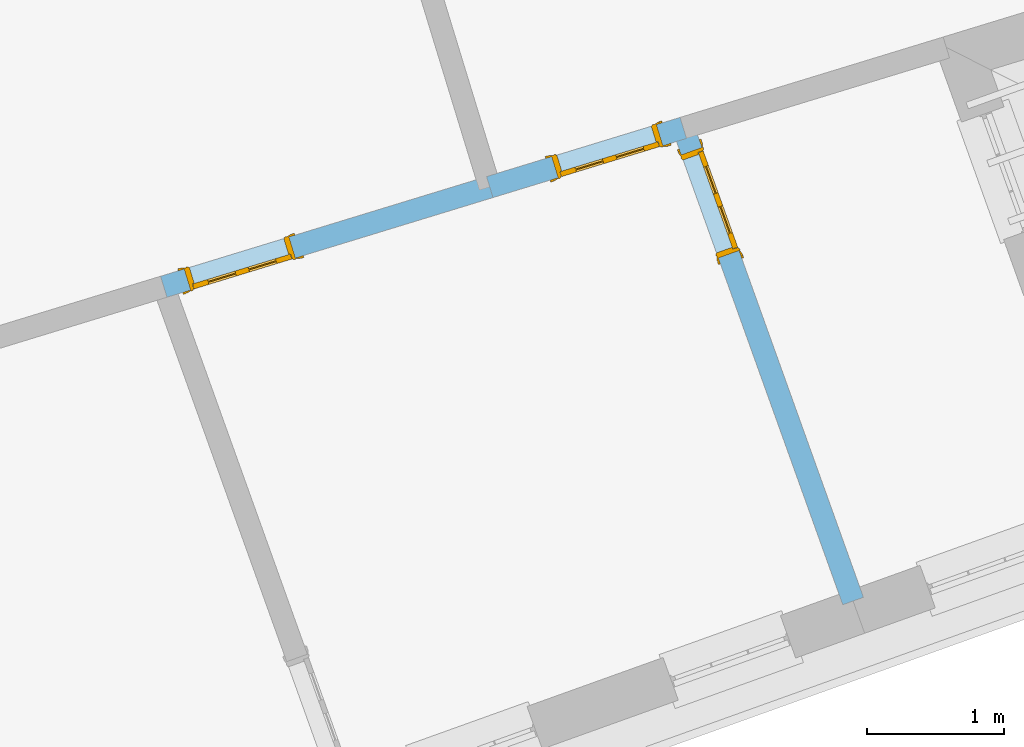
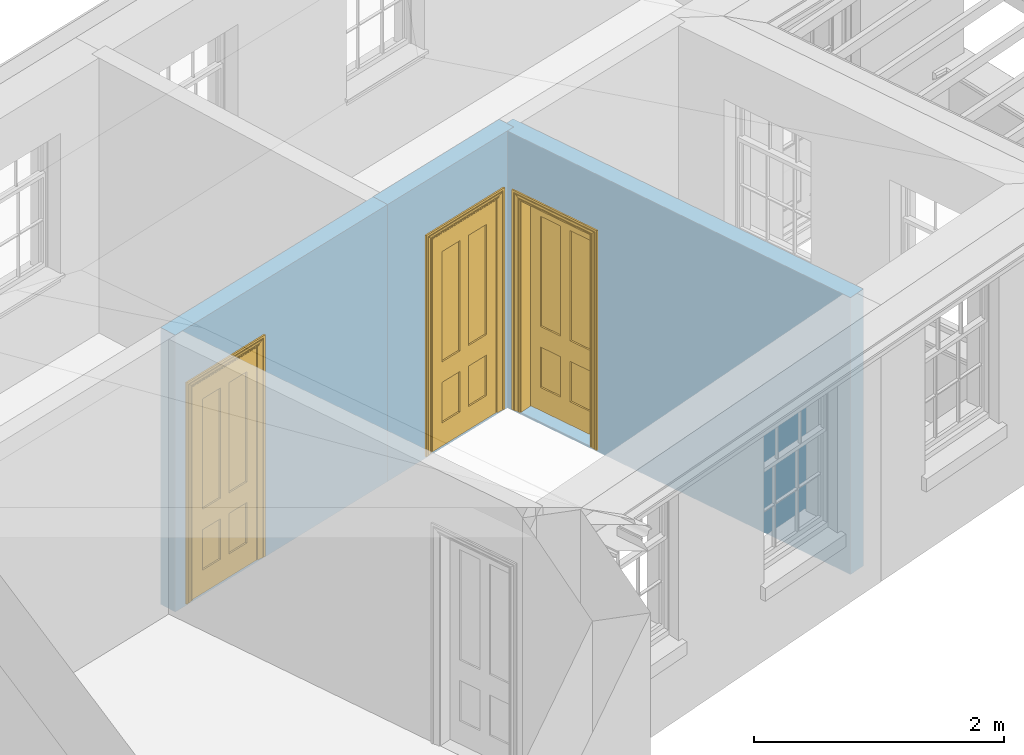
# One storey, part 5 of 10: 3 doors, 3 openings, plus 3 elements that do not belong to this part.
"""IFC2X3 building model written with IfcOpenShell, lengths in metres."""

from ifc_helpers import new_model, si_unit, frame, origin, place, context, subcontext, project, spatial, polyline, outline, extrude, faceted_brep, material, layer, layer_set, layer_usage, element, fill, save


model = new_model("IFC2X3")

# Units and contexts
model_context = context("Model", 3, world=origin())
body_context = subcontext(model_context, "Body", "Model", "MODEL_VIEW")
ifc_project = project(units=[si_unit("PLANEANGLEUNIT", "RADIAN"), si_unit("MASSUNIT", "GRAM", prefix="KILO"), si_unit("FORCEUNIT", "NEWTON", prefix="KILO"), si_unit("LENGTHUNIT", "METRE")], contexts=[model_context])

# Site, building, storey
site_placement = place(None, origin())
site = spatial("IfcSite", under=ifc_project, at=site_placement, CompositionType="ELEMENT")
building_placement = place(None, origin())
building = spatial("IfcBuilding", under=site, at=building_placement, Name="Building plot-9", CompositionType="ELEMENT")
storey_placement = place(None, frame((0.0, 0.0, 4.3)))
storey = spatial("IfcBuildingStorey", under=building, at=storey_placement, Name="Floor 1", CompositionType="ELEMENT", Elevation=4.3)

# Wall, opening, door
ifc_material = material(Name="Masonry")
ifc_layer = layer(ifc_material, 0.16, ventilated=False)
ifc_layer_set = layer_set([ifc_layer], Name="My Wall")
ifc_layer_usage = layer_usage(ifc_layer_set, "AXIS2", "NEGATIVE", 0.08)
wall_1_placement = place(storey_placement, origin())
wall_1 = element("IfcWallStandardCase", 1, at=wall_1_placement, inside=storey, material=ifc_layer_usage, Name="interior", context=body_context, shape_type="SweptSolid", body=[
    extrude(outline(polyline([(36.3823365784182, 19.2169448734057), (36.3355604715048, 19.3699546633605), (34.9235636395364, 18.9382978733414), (34.9703397464498, 18.7852880833866), (36.3823365784182, 19.2169448734057)])), origin(), (0.0, 0.0, 1.0), 2.7),
])
opening_1_placement = place(storey_placement, frame((0.0, 0.0, 0.0199999999999996)))
opening_1 = element("IfcOpeningElement", 2, at=opening_1_placement, cuts=wall_1, Name="Opening", ObjectType="Opening", context=body_context, shape_type="SweptSolid", body=[
    extrude(outline(polyline([(36.1634244578056, 19.3173315430831), (35.3983755080313, 19.0834510085165), (35.4451516149446, 18.9304412185616), (36.2102005647189, 19.1643217531282), (36.1634244578056, 19.3173315430831)])), origin(), (0.0, 0.0, 1.0), 2.1),
])
door_1_placement = place(storey_placement, frame((36.1868125112623, 19.2408266481056, 0.0199999999999996), z_axis=(0.0, 0.0, 1.0), x_axis=(-0.765048949774361, -0.233880534566577, 0.0)))
door_1 = element("IfcDoor", 3, at=door_1_placement, inside=storey, Name="bedroom inside door", OverallHeight=2.1, OverallWidth=0.8, context=body_context, shape_type="Brep", held_by="IfcProductRepresentation", body=[
    faceted_brep([(0.773, 0.08, 1.895), (0.66, 0.08, 1.895), (0.66, 0.08, 2.073), (0.773, 0.08, 2.073), (0.773, 0.08, 0.82), (0.66, 0.08, 0.82), (0.45, 0.08, 1.895), (0.45, 0.08, 2.073), (0.773, 0.08, 0.62), (0.66, 0.08, 0.62), (0.66, 0.065, 0.82), (0.66, 0.065, 1.895), (0.45, 0.065, 1.895), (0.35, 0.08, 1.895), (0.35, 0.08, 2.073), (0.773, 0.08, 0.225), (0.66, 0.08, 0.225), (0.45, 0.08, 0.62), (0.45, 0.08, 0.82), (0.45, 0.065, 0.82), (0.35, 0.08, 0.82), (0.14, 0.08, 2.073), (0.14, 0.08, 1.895), (0.773, 0.08, 0.0), (0.66, 0.08, 0.0), (0.66, 0.065, 0.225), (0.66, 0.065, 0.62), (0.45, 0.065, 0.62), (0.35, 0.08, 0.62), (0.35, 0.065, 0.82), (0.35, 0.065, 1.895), (0.14, 0.065, 1.895), (0.027, 0.08, 2.073), (0.027, 0.08, 1.895), (0.773, 0.042, 0.0), (0.66, 0.042, 0.0), (0.45, 0.08, 0.0), (0.45, 0.08, 0.225), (0.45, 0.065, 0.225), (0.35, 0.08, 0.225), (0.14, 0.08, 0.82), (0.14, 0.08, 0.62), (0.14, 0.065, 0.82), (0.027, 0.08, 0.82), (0.773, 0.042, 0.225), (0.66, 0.042, 0.225), (0.45, 0.042, 0.0), (0.35, 0.08, 0.0), (0.35, 0.065, 0.225), (0.35, 0.065, 0.62), (0.14, 0.065, 0.62), (0.027, 0.08, 0.62), (0.773, 0.042, 0.62), (0.66, 0.042, 0.62), (0.45, 0.042, 0.225), (0.35, 0.042, 0.0), (0.14, 0.08, 0.225), (0.14, 0.08, 0.0), (0.14, 0.065, 0.225), (0.027, 0.08, 0.225), (0.773, 0.042, 0.82), (0.66, 0.042, 0.82), (0.66, 0.057, 0.62), (0.66, 0.057, 0.225), (0.45, 0.057, 0.225), (0.35, 0.042, 0.225), (0.14, 0.042, 0.0), (0.027, 0.08, 0.0), (0.773, 0.042, 1.895), (0.66, 0.042, 1.895), (0.45, 0.042, 0.62), (0.45, 0.042, 0.82), (0.45, 0.057, 0.62), (0.35, 0.042, 0.62), (0.14, 0.042, 0.225), (0.027, 0.042, 0.0), (0.773, 0.042, 2.073), (0.66, 0.042, 2.073), (0.66, 0.057, 1.895), (0.66, 0.057, 0.82), (0.45, 0.057, 0.82), (0.35, 0.042, 0.82), (0.35, 0.057, 0.62), (0.35, 0.057, 0.225), (0.14, 0.057, 0.225), (0.027, 0.042, 0.225), (0.45, 0.042, 1.895), (0.45, 0.042, 2.073), (0.45, 0.057, 1.895), (0.35, 0.042, 1.895), (0.14, 0.042, 0.82), (0.14, 0.042, 0.62), (0.14, 0.057, 0.62), (0.027, 0.042, 0.62), (0.35, 0.042, 2.073), (0.35, 0.057, 1.895), (0.35, 0.057, 0.82), (0.14, 0.057, 0.82), (0.027, 0.042, 0.82), (0.14, 0.042, 2.073), (0.14, 0.042, 1.895), (0.14, 0.057, 1.895), (0.027, 0.042, 1.895), (0.027, 0.042, 2.073), (0.02, 0.085, 0.0), (0.005, 0.09, 0.0), (0.005, 0.09, 2.095), (0.02, 0.085, 2.08), (0.02, 0.08, 0.0), (0.0, 0.085, 0.0), (0.0, 0.085, 2.1), (0.795, 0.09, 2.095), (0.78, 0.085, 2.08), (0.02, 0.08, 2.08), (0.0, 0.08, 0.0), (-0.032, 0.095, 0.0), (-0.032, 0.095, 2.132), (0.8, 0.085, 2.1), (0.795, 0.09, 0.0), (0.78, 0.085, 0.0), (0.78, 0.08, 2.08), (0.04, 0.04, 0.0), (0.025, 0.04, 0.0), (0.025, 0.04, 2.075), (0.04, 0.04, 2.06), (-0.04, 0.09, 0.0), (-0.04, 0.09, 2.14), (0.832, 0.095, 2.132), (0.8, 0.085, 0.0), (0.78, 0.08, 0.0), (0.8, 0.08, 0.0), (0.86, 0.08, 0.0), (0.86, 0.08, 2.16), (0.8, 0.08, 2.1), (-0.06, 0.08, 2.16), (0.0, 0.08, 2.1), (-0.06, 0.08, 0.0), (-0.04, 0.095, 0.0), (-0.04, 0.095, 2.14), (0.84, 0.09, 2.14), (0.832, 0.095, 0.0), (0.84, 0.09, 0.0), (0.86, 0.095, 0.0), (0.86, 0.095, 2.16), (-0.06, 0.095, 2.16), (-0.06, 0.095, 0.0), (0.84, 0.095, 0.0), (0.84, 0.095, 2.14), (-0.025, -0.095, 0.0), (-0.025, -0.09, 0.0), (-0.025, -0.09, 2.125), (-0.025, -0.095, 2.125), (-0.017, -0.095, 0.0), (-0.017, -0.095, 2.117), (0.825, -0.09, 2.125), (0.825, -0.095, 2.125), (0.825, -0.095, 0.0), (0.845, -0.095, 0.0), (-0.045, -0.095, 2.145), (-0.045, -0.095, 0.0), (0.845, -0.095, 2.145), (0.015, -0.085, 0.0), (0.015, -0.085, 2.085), (0.817, -0.095, 2.117), (0.825, -0.09, 0.0), (0.845, -0.08, 0.0), (0.845, -0.08, 2.145), (-0.045, -0.08, 2.145), (-0.045, -0.08, 0.0), (0.02, -0.09, 0.0), (0.02, -0.09, 2.08), (0.785, -0.085, 2.085), (0.817, -0.095, 0.0), (0.8, -0.08, 0.0), (0.8, -0.08, 2.1), (0.0, -0.08, 2.1), (0.0, -0.08, 0.0), (0.035, -0.085, 0.0), (0.035, -0.085, 2.065), (0.78, -0.09, 2.08), (0.785, -0.085, 0.0), (0.775, 0.04, 2.075), (0.76, 0.04, 2.06), (0.035, -0.08, 2.065), (0.035, -0.08, 0.0), (0.765, -0.085, 2.065), (0.78, -0.09, 0.0), (0.765, -0.08, 0.0), (0.765, -0.08, 2.065), (0.765, -0.085, 0.0), (0.04, -0.08, 2.06), (0.04, -0.08, 0.0), (0.76, -0.08, 2.06), (0.76, -0.08, 0.0), (0.76, 0.04, 0.0), (0.775, 0.04, 0.0), (0.025, 0.08, 0.0), (0.025, 0.08, 2.075), (0.775, 0.08, 0.0), (0.775, 0.08, 2.075)], [[[0, 1, 2, 3]], [[1, 0, 4, 5]], [[1, 6, 7, 2]], [[8, 9, 5, 4]], [[1, 5, 10, 11]], [[6, 1, 11, 12]], [[6, 13, 14, 7]], [[15, 16, 9, 8]], [[9, 17, 18, 5]], [[5, 18, 19, 10]], [[10, 19, 12, 11]], [[18, 6, 12, 19]], [[18, 20, 13, 6]], [[21, 14, 13, 22]], [[23, 24, 16, 15]], [[9, 16, 25, 26]], [[17, 9, 26, 27]], [[17, 28, 20, 18]], [[13, 20, 29, 30]], [[22, 13, 30, 31]], [[32, 21, 22, 33]], [[34, 35, 24, 23]], [[24, 36, 37, 16]], [[16, 37, 38, 25]], [[25, 38, 27, 26]], [[37, 17, 27, 38]], [[37, 39, 28, 17]], [[40, 20, 28, 41]], [[20, 40, 42, 29]], [[31, 30, 29, 42]], [[40, 22, 31, 42]], [[33, 22, 40, 43]], [[35, 34, 44, 45]], [[35, 46, 36, 24]], [[36, 47, 39, 37]], [[28, 39, 48, 49]], [[41, 28, 49, 50]], [[43, 40, 41, 51]], [[45, 44, 52, 53]], [[46, 35, 45, 54]], [[46, 55, 47, 36]], [[56, 39, 47, 57]], [[39, 56, 58, 48]], [[50, 49, 48, 58]], [[56, 41, 50, 58]], [[51, 41, 56, 59]], [[53, 52, 60, 61]], [[45, 53, 62, 63]], [[54, 45, 63, 64]], [[55, 46, 54, 65]], [[55, 66, 57, 47]], [[59, 56, 57, 67]], [[61, 60, 68, 69]], [[70, 53, 61, 71]], [[53, 70, 72, 62]], [[72, 64, 63, 62]], [[70, 54, 64, 72]], [[65, 54, 70, 73]], [[65, 74, 66, 55]], [[67, 57, 66, 75]], [[69, 68, 76, 77]], [[61, 69, 78, 79]], [[71, 61, 79, 80]], [[73, 70, 71, 81]], [[65, 73, 82, 83]], [[74, 65, 83, 84]], [[74, 85, 75, 66]], [[86, 69, 77, 87]], [[69, 86, 88, 78]], [[88, 80, 79, 78]], [[86, 71, 80, 88]], [[81, 71, 86, 89]], [[73, 81, 90, 91]], [[73, 91, 92, 82]], [[83, 82, 92, 84]], [[91, 74, 84, 92]], [[91, 93, 85, 74]], [[89, 86, 87, 94]], [[81, 89, 95, 96]], [[90, 81, 96, 97]], [[90, 98, 93, 91]], [[94, 99, 100, 89]], [[89, 100, 101, 95]], [[101, 97, 96, 95]], [[100, 90, 97, 101]], [[100, 102, 98, 90]], [[99, 103, 102, 100]], [[32, 103, 99, 21]], [[102, 103, 32, 33]], [[98, 102, 33, 43]], [[21, 99, 94, 14]], [[94, 87, 7, 14]], [[7, 87, 77, 2]], [[76, 3, 2, 77]], [[43, 51, 93, 98]], [[51, 59, 85, 93]], [[67, 75, 85, 59]], [[34, 23, 15, 44]], [[44, 15, 8, 52]], [[52, 8, 4, 60]], [[0, 68, 60, 4]], [[0, 3, 76, 68]], [[104, 105, 106, 107]], [[104, 108, 109, 105]], [[105, 109, 110, 106]], [[107, 106, 111, 112]], [[107, 113, 108, 104]], [[114, 109, 108]], [[109, 115, 116, 110]], [[106, 110, 117, 111]], [[112, 111, 118, 119]], [[113, 107, 112, 120]], [[121, 122, 123, 124]], [[115, 109, 114, 125]], [[115, 125, 126, 116]], [[110, 116, 127, 117]], [[111, 117, 128, 118]], [[118, 128, 129, 119]], [[120, 112, 119, 129]], [[130, 129, 128]], [[130, 131, 132, 133]], [[133, 132, 134, 135]], [[135, 134, 136, 114]], [[136, 125, 114]], [[125, 137, 138, 126]], [[116, 126, 139, 127]], [[117, 127, 140, 128]], [[141, 130, 128, 140]], [[131, 130, 141]], [[131, 142, 143, 132]], [[132, 143, 144, 134]], [[134, 144, 145, 136]], [[137, 125, 136, 145]], [[143, 142, 146]], [[143, 146, 147]], [[137, 145, 144]], [[143, 147, 138]], [[138, 137, 144]], [[143, 138, 144]], [[126, 138, 147, 139]], [[127, 139, 141, 140]], [[142, 131, 141, 146]], [[139, 147, 146, 141]], [[148, 149, 150, 151]], [[149, 152, 153, 150]], [[151, 150, 154, 155]], [[155, 156, 157]], [[158, 159, 148]], [[158, 148, 151]], [[155, 157, 160]], [[158, 151, 155]], [[155, 160, 158]], [[152, 161, 162, 153]], [[150, 153, 163, 154]], [[155, 154, 164, 156]], [[156, 164, 165, 157]], [[157, 165, 166, 160]], [[160, 166, 167, 158]], [[158, 167, 168, 159]], [[161, 169, 170, 162]], [[153, 162, 171, 163]], [[154, 163, 172, 164]], [[165, 164, 173]], [[165, 173, 174, 166]], [[166, 174, 175, 167]], [[167, 175, 176, 168]], [[169, 177, 178, 170]], [[162, 170, 179, 171]], [[163, 171, 180, 172]], [[172, 180, 173, 164]], [[124, 123, 181, 182]], [[183, 178, 177, 184]], [[170, 178, 185, 179]], [[171, 179, 186, 180]], [[187, 173, 180]], [[185, 188, 187, 189]], [[188, 185, 178, 183]], [[179, 185, 189, 186]], [[189, 187, 180, 186]], [[190, 183, 184, 191]], [[192, 188, 183, 190]], [[191, 184, 122, 121]], [[124, 190, 191, 121]], [[193, 187, 188, 192]], [[182, 192, 190, 124]], [[184, 176, 122]], [[194, 195, 187, 193]], [[192, 182, 194, 193]], [[161, 176, 184]], [[114, 108, 122, 176]], [[173, 187, 195]], [[152, 149, 176, 161]], [[169, 161, 184, 177]], [[196, 122, 108]], [[176, 175, 135, 114]], [[173, 195, 129, 130]], [[176, 149, 168]], [[123, 122, 196, 197]], [[196, 108, 113, 197]], [[175, 174, 133, 135]], [[198, 129, 195]], [[133, 174, 173, 130]], [[159, 168, 149, 148]], [[181, 123, 197, 199]], [[197, 113, 120, 199]], [[199, 120, 129, 198]], [[195, 181, 199, 198]], [[195, 194, 182, 181]]]),
])
fill(opening_1, door_1)

wall_2_placement = place(storey_placement, origin())
wall_2 = element("IfcWallStandardCase", 4, at=wall_2_placement, inside=storey, material=ifc_layer_usage, Name="interior", context=body_context, shape_type="SweptSolid", body=[
    extrude(outline(polyline([(36.4342442893172, 19.3204784174447), (36.2836527606058, 19.2664211193215), (37.5228374656723, 15.8143299943324), (37.6734289943837, 15.8683872924556), (36.4342442893172, 19.3204784174447)])), origin(), (0.0, 0.0, 1.0), 2.7),
])
opening_2_placement = place(storey_placement, frame((0.0, 0.0, 0.0199999999999996)))
opening_2 = element("IfcOpeningElement", 5, at=opening_2_placement, cuts=wall_2, Name="Opening", ObjectType="Opening", context=body_context, shape_type="SweptSolid", body=[
    extrude(outline(polyline([(36.3444672209943, 19.0970056495212), (36.6147537116099, 18.3440480059644), (36.7653452403213, 18.3981053040875), (36.4950587497057, 19.1510629476444), (36.3444672209943, 19.0970056495212)])), origin(), (0.0, 0.0, 1.0), 2.1),
])
door_2_placement = place(storey_placement, frame((36.41976298535, 19.1240342985828, 0.0199999999999996), z_axis=(0.0, 0.0, 1.0), x_axis=(0.270286490615604, -0.752957643556858, 0.0)))
door_2 = element("IfcDoor", 6, at=door_2_placement, inside=storey, Name="toilet inside door", OverallHeight=2.1, OverallWidth=0.8, context=body_context, shape_type="Brep", held_by="IfcProductRepresentation", body=[
    faceted_brep([(0.773, 0.08, 1.895), (0.66, 0.08, 1.895), (0.66, 0.08, 2.073), (0.773, 0.08, 2.073), (0.773, 0.08, 0.82), (0.66, 0.08, 0.82), (0.45, 0.08, 1.895), (0.45, 0.08, 2.073), (0.773, 0.08, 0.62), (0.66, 0.08, 0.62), (0.66, 0.065, 0.82), (0.66, 0.065, 1.895), (0.45, 0.065, 1.895), (0.35, 0.08, 1.895), (0.35, 0.08, 2.073), (0.773, 0.08, 0.225), (0.66, 0.08, 0.225), (0.45, 0.08, 0.62), (0.45, 0.08, 0.82), (0.45, 0.065, 0.82), (0.35, 0.08, 0.82), (0.14, 0.08, 2.073), (0.14, 0.08, 1.895), (0.773, 0.08, 0.0), (0.66, 0.08, 0.0), (0.66, 0.065, 0.225), (0.66, 0.065, 0.62), (0.45, 0.065, 0.62), (0.35, 0.08, 0.62), (0.35, 0.065, 0.82), (0.35, 0.065, 1.895), (0.14, 0.065, 1.895), (0.027, 0.08, 2.073), (0.027, 0.08, 1.895), (0.773, 0.042, 0.0), (0.66, 0.042, 0.0), (0.45, 0.08, 0.0), (0.45, 0.08, 0.225), (0.45, 0.065, 0.225), (0.35, 0.08, 0.225), (0.14, 0.08, 0.82), (0.14, 0.08, 0.62), (0.14, 0.065, 0.82), (0.027, 0.08, 0.82), (0.773, 0.042, 0.225), (0.66, 0.042, 0.225), (0.45, 0.042, 0.0), (0.35, 0.08, 0.0), (0.35, 0.065, 0.225), (0.35, 0.065, 0.62), (0.14, 0.065, 0.62), (0.027, 0.08, 0.62), (0.773, 0.042, 0.62), (0.66, 0.042, 0.62), (0.45, 0.042, 0.225), (0.35, 0.042, 0.0), (0.14, 0.08, 0.225), (0.14, 0.08, 0.0), (0.14, 0.065, 0.225), (0.027, 0.08, 0.225), (0.773, 0.042, 0.82), (0.66, 0.042, 0.82), (0.66, 0.057, 0.62), (0.66, 0.057, 0.225), (0.45, 0.057, 0.225), (0.35, 0.042, 0.225), (0.14, 0.042, 0.0), (0.027, 0.08, 0.0), (0.773, 0.042, 1.895), (0.66, 0.042, 1.895), (0.45, 0.042, 0.62), (0.45, 0.042, 0.82), (0.45, 0.057, 0.62), (0.35, 0.042, 0.62), (0.14, 0.042, 0.225), (0.027, 0.042, 0.0), (0.773, 0.042, 2.073), (0.66, 0.042, 2.073), (0.66, 0.057, 1.895), (0.66, 0.057, 0.82), (0.45, 0.057, 0.82), (0.35, 0.042, 0.82), (0.35, 0.057, 0.62), (0.35, 0.057, 0.225), (0.14, 0.057, 0.225), (0.027, 0.042, 0.225), (0.45, 0.042, 1.895), (0.45, 0.042, 2.073), (0.45, 0.057, 1.895), (0.35, 0.042, 1.895), (0.14, 0.042, 0.82), (0.14, 0.042, 0.62), (0.14, 0.057, 0.62), (0.027, 0.042, 0.62), (0.35, 0.042, 2.073), (0.35, 0.057, 1.895), (0.35, 0.057, 0.82), (0.14, 0.057, 0.82), (0.027, 0.042, 0.82), (0.14, 0.042, 2.073), (0.14, 0.042, 1.895), (0.14, 0.057, 1.895), (0.027, 0.042, 1.895), (0.027, 0.042, 2.073), (0.02, 0.085, 0.0), (0.005, 0.09, 0.0), (0.005, 0.09, 2.095), (0.02, 0.085, 2.08), (0.02, 0.08, 0.0), (0.0, 0.085, 0.0), (0.0, 0.085, 2.1), (0.795, 0.09, 2.095), (0.78, 0.085, 2.08), (0.02, 0.08, 2.08), (0.0, 0.08, 0.0), (-0.032, 0.095, 0.0), (-0.032, 0.095, 2.132), (0.8, 0.085, 2.1), (0.795, 0.09, 0.0), (0.78, 0.085, 0.0), (0.78, 0.08, 2.08), (0.04, 0.04, 0.0), (0.025, 0.04, 0.0), (0.025, 0.04, 2.075), (0.04, 0.04, 2.06), (-0.04, 0.09, 0.0), (-0.04, 0.09, 2.14), (0.832, 0.095, 2.132), (0.8, 0.085, 0.0), (0.78, 0.08, 0.0), (0.8, 0.08, 0.0), (0.86, 0.08, 0.0), (0.86, 0.08, 2.16), (0.8, 0.08, 2.1), (-0.06, 0.08, 2.16), (0.0, 0.08, 2.1), (-0.06, 0.08, 0.0), (-0.04, 0.095, 0.0), (-0.04, 0.095, 2.14), (0.84, 0.09, 2.14), (0.832, 0.095, 0.0), (0.84, 0.09, 0.0), (0.86, 0.095, 0.0), (0.86, 0.095, 2.16), (-0.06, 0.095, 2.16), (-0.06, 0.095, 0.0), (0.84, 0.095, 0.0), (0.84, 0.095, 2.14), (-0.025, -0.095, 0.0), (-0.025, -0.09, 0.0), (-0.025, -0.09, 2.125), (-0.025, -0.095, 2.125), (-0.017, -0.095, 0.0), (-0.017, -0.095, 2.117), (0.825, -0.09, 2.125), (0.825, -0.095, 2.125), (0.825, -0.095, 0.0), (0.845, -0.095, 0.0), (-0.045, -0.095, 2.145), (-0.045, -0.095, 0.0), (0.845, -0.095, 2.145), (0.015, -0.085, 0.0), (0.015, -0.085, 2.085), (0.817, -0.095, 2.117), (0.825, -0.09, 0.0), (0.845, -0.08, 0.0), (0.845, -0.08, 2.145), (-0.045, -0.08, 2.145), (-0.045, -0.08, 0.0), (0.02, -0.09, 0.0), (0.02, -0.09, 2.08), (0.785, -0.085, 2.085), (0.817, -0.095, 0.0), (0.8, -0.08, 0.0), (0.8, -0.08, 2.1), (0.0, -0.08, 2.1), (0.0, -0.08, 0.0), (0.035, -0.085, 0.0), (0.035, -0.085, 2.065), (0.78, -0.09, 2.08), (0.785, -0.085, 0.0), (0.775, 0.04, 2.075), (0.76, 0.04, 2.06), (0.035, -0.08, 2.065), (0.035, -0.08, 0.0), (0.765, -0.085, 2.065), (0.78, -0.09, 0.0), (0.765, -0.08, 0.0), (0.765, -0.08, 2.065), (0.765, -0.085, 0.0), (0.04, -0.08, 2.06), (0.04, -0.08, 0.0), (0.76, -0.08, 2.06), (0.76, -0.08, 0.0), (0.76, 0.04, 0.0), (0.775, 0.04, 0.0), (0.025, 0.08, 0.0), (0.025, 0.08, 2.075), (0.775, 0.08, 0.0), (0.775, 0.08, 2.075)], [[[0, 1, 2, 3]], [[1, 0, 4, 5]], [[1, 6, 7, 2]], [[8, 9, 5, 4]], [[1, 5, 10, 11]], [[6, 1, 11, 12]], [[6, 13, 14, 7]], [[15, 16, 9, 8]], [[9, 17, 18, 5]], [[5, 18, 19, 10]], [[10, 19, 12, 11]], [[18, 6, 12, 19]], [[18, 20, 13, 6]], [[21, 14, 13, 22]], [[23, 24, 16, 15]], [[9, 16, 25, 26]], [[17, 9, 26, 27]], [[17, 28, 20, 18]], [[13, 20, 29, 30]], [[22, 13, 30, 31]], [[32, 21, 22, 33]], [[34, 35, 24, 23]], [[24, 36, 37, 16]], [[16, 37, 38, 25]], [[25, 38, 27, 26]], [[37, 17, 27, 38]], [[37, 39, 28, 17]], [[40, 20, 28, 41]], [[20, 40, 42, 29]], [[31, 30, 29, 42]], [[40, 22, 31, 42]], [[33, 22, 40, 43]], [[35, 34, 44, 45]], [[35, 46, 36, 24]], [[36, 47, 39, 37]], [[28, 39, 48, 49]], [[41, 28, 49, 50]], [[43, 40, 41, 51]], [[45, 44, 52, 53]], [[46, 35, 45, 54]], [[46, 55, 47, 36]], [[56, 39, 47, 57]], [[39, 56, 58, 48]], [[50, 49, 48, 58]], [[56, 41, 50, 58]], [[51, 41, 56, 59]], [[53, 52, 60, 61]], [[45, 53, 62, 63]], [[54, 45, 63, 64]], [[55, 46, 54, 65]], [[55, 66, 57, 47]], [[59, 56, 57, 67]], [[61, 60, 68, 69]], [[70, 53, 61, 71]], [[53, 70, 72, 62]], [[72, 64, 63, 62]], [[70, 54, 64, 72]], [[65, 54, 70, 73]], [[65, 74, 66, 55]], [[67, 57, 66, 75]], [[69, 68, 76, 77]], [[61, 69, 78, 79]], [[71, 61, 79, 80]], [[73, 70, 71, 81]], [[65, 73, 82, 83]], [[74, 65, 83, 84]], [[74, 85, 75, 66]], [[86, 69, 77, 87]], [[69, 86, 88, 78]], [[88, 80, 79, 78]], [[86, 71, 80, 88]], [[81, 71, 86, 89]], [[73, 81, 90, 91]], [[73, 91, 92, 82]], [[83, 82, 92, 84]], [[91, 74, 84, 92]], [[91, 93, 85, 74]], [[89, 86, 87, 94]], [[81, 89, 95, 96]], [[90, 81, 96, 97]], [[90, 98, 93, 91]], [[94, 99, 100, 89]], [[89, 100, 101, 95]], [[101, 97, 96, 95]], [[100, 90, 97, 101]], [[100, 102, 98, 90]], [[99, 103, 102, 100]], [[32, 103, 99, 21]], [[102, 103, 32, 33]], [[98, 102, 33, 43]], [[21, 99, 94, 14]], [[94, 87, 7, 14]], [[7, 87, 77, 2]], [[76, 3, 2, 77]], [[43, 51, 93, 98]], [[51, 59, 85, 93]], [[67, 75, 85, 59]], [[34, 23, 15, 44]], [[44, 15, 8, 52]], [[52, 8, 4, 60]], [[0, 68, 60, 4]], [[0, 3, 76, 68]], [[104, 105, 106, 107]], [[104, 108, 109, 105]], [[105, 109, 110, 106]], [[107, 106, 111, 112]], [[107, 113, 108, 104]], [[114, 109, 108]], [[109, 115, 116, 110]], [[106, 110, 117, 111]], [[112, 111, 118, 119]], [[113, 107, 112, 120]], [[121, 122, 123, 124]], [[115, 109, 114, 125]], [[115, 125, 126, 116]], [[110, 116, 127, 117]], [[111, 117, 128, 118]], [[118, 128, 129, 119]], [[120, 112, 119, 129]], [[130, 129, 128]], [[130, 131, 132, 133]], [[133, 132, 134, 135]], [[135, 134, 136, 114]], [[136, 125, 114]], [[125, 137, 138, 126]], [[116, 126, 139, 127]], [[117, 127, 140, 128]], [[141, 130, 128, 140]], [[131, 130, 141]], [[131, 142, 143, 132]], [[132, 143, 144, 134]], [[134, 144, 145, 136]], [[137, 125, 136, 145]], [[143, 142, 146]], [[143, 146, 147]], [[137, 145, 144]], [[143, 147, 138]], [[138, 137, 144]], [[143, 138, 144]], [[126, 138, 147, 139]], [[127, 139, 141, 140]], [[142, 131, 141, 146]], [[139, 147, 146, 141]], [[148, 149, 150, 151]], [[149, 152, 153, 150]], [[151, 150, 154, 155]], [[155, 156, 157]], [[158, 159, 148]], [[158, 148, 151]], [[155, 157, 160]], [[158, 151, 155]], [[155, 160, 158]], [[152, 161, 162, 153]], [[150, 153, 163, 154]], [[155, 154, 164, 156]], [[156, 164, 165, 157]], [[157, 165, 166, 160]], [[160, 166, 167, 158]], [[158, 167, 168, 159]], [[161, 169, 170, 162]], [[153, 162, 171, 163]], [[154, 163, 172, 164]], [[165, 164, 173]], [[165, 173, 174, 166]], [[166, 174, 175, 167]], [[167, 175, 176, 168]], [[169, 177, 178, 170]], [[162, 170, 179, 171]], [[163, 171, 180, 172]], [[172, 180, 173, 164]], [[124, 123, 181, 182]], [[183, 178, 177, 184]], [[170, 178, 185, 179]], [[171, 179, 186, 180]], [[187, 173, 180]], [[185, 188, 187, 189]], [[188, 185, 178, 183]], [[179, 185, 189, 186]], [[189, 187, 180, 186]], [[190, 183, 184, 191]], [[192, 188, 183, 190]], [[191, 184, 122, 121]], [[124, 190, 191, 121]], [[193, 187, 188, 192]], [[182, 192, 190, 124]], [[184, 176, 122]], [[194, 195, 187, 193]], [[192, 182, 194, 193]], [[161, 176, 184]], [[114, 108, 122, 176]], [[173, 187, 195]], [[152, 149, 176, 161]], [[169, 161, 184, 177]], [[196, 122, 108]], [[176, 175, 135, 114]], [[173, 195, 129, 130]], [[176, 149, 168]], [[123, 122, 196, 197]], [[196, 108, 113, 197]], [[175, 174, 133, 135]], [[198, 129, 195]], [[133, 174, 173, 130]], [[159, 168, 149, 148]], [[181, 123, 197, 199]], [[197, 113, 120, 199]], [[199, 120, 129, 198]], [[195, 181, 199, 198]], [[195, 194, 182, 181]]]),
])
fill(opening_2, door_2)

wall_3_placement = place(storey_placement, origin())
wall_3 = element("IfcWallStandardCase", 7, at=wall_3_placement, inside=storey, material=ifc_layer_usage, Name="interior", context=body_context, shape_type="SweptSolid", body=[
    extrude(outline(polyline([(34.9703397464498, 18.7852880833866), (34.9235636395364, 18.9382978733414), (32.5445375127484, 18.2110138185823), (32.5913136196618, 18.0580040286275), (34.9703397464498, 18.7852880833866)])), origin(), (0.0, 0.0, 1.0), 2.7),
])
opening_3_placement = place(storey_placement, frame((0.0, 0.0, 0.0199999999999996)))
opening_3 = element("IfcOpeningElement", 8, at=opening_3_placement, cuts=wall_3, Name="Opening", ObjectType="Opening", context=body_context, shape_type="SweptSolid", body=[
    extrude(outline(polyline([(33.481722476222, 18.4975174734264), (32.7166735264477, 18.2636369388598), (32.763449633361, 18.1106271489049), (33.5284985831353, 18.3445076834715), (33.481722476222, 18.4975174734264)])), origin(), (0.0, 0.0, 1.0), 2.1),
])
door_3_placement = place(storey_placement, frame((33.5051105296787, 18.421012578449, 0.0199999999999996), z_axis=(0.0, 0.0, 1.0), x_axis=(-0.765048949774354, -0.233880534566598, 0.0)))
door_3 = element("IfcDoor", 9, at=door_3_placement, inside=storey, Name="bedroom inside door", OverallHeight=2.1, OverallWidth=0.8, context=body_context, shape_type="Brep", held_by="IfcProductRepresentation", body=[
    faceted_brep([(0.773, 0.08, 1.895), (0.66, 0.08, 1.895), (0.66, 0.08, 2.073), (0.773, 0.08, 2.073), (0.773, 0.08, 0.82), (0.66, 0.08, 0.82), (0.45, 0.08, 1.895), (0.45, 0.08, 2.073), (0.773, 0.08, 0.62), (0.66, 0.08, 0.62), (0.66, 0.065, 0.82), (0.66, 0.065, 1.895), (0.45, 0.065, 1.895), (0.35, 0.08, 1.895), (0.35, 0.08, 2.073), (0.773, 0.08, 0.225), (0.66, 0.08, 0.225), (0.45, 0.08, 0.62), (0.45, 0.08, 0.82), (0.45, 0.065, 0.82), (0.35, 0.08, 0.82), (0.14, 0.08, 2.073), (0.14, 0.08, 1.895), (0.773, 0.08, 0.0), (0.66, 0.08, 0.0), (0.66, 0.065, 0.225), (0.66, 0.065, 0.62), (0.45, 0.065, 0.62), (0.35, 0.08, 0.62), (0.35, 0.065, 0.82), (0.35, 0.065, 1.895), (0.14, 0.065, 1.895), (0.027, 0.08, 2.073), (0.027, 0.08, 1.895), (0.773, 0.042, 0.0), (0.66, 0.042, 0.0), (0.45, 0.08, 0.0), (0.45, 0.08, 0.225), (0.45, 0.065, 0.225), (0.35, 0.08, 0.225), (0.14, 0.08, 0.82), (0.14, 0.08, 0.62), (0.14, 0.065, 0.82), (0.027, 0.08, 0.82), (0.773, 0.042, 0.225), (0.66, 0.042, 0.225), (0.45, 0.042, 0.0), (0.35, 0.08, 0.0), (0.35, 0.065, 0.225), (0.35, 0.065, 0.62), (0.14, 0.065, 0.62), (0.027, 0.08, 0.62), (0.773, 0.042, 0.62), (0.66, 0.042, 0.62), (0.45, 0.042, 0.225), (0.35, 0.042, 0.0), (0.14, 0.08, 0.225), (0.14, 0.08, 0.0), (0.14, 0.065, 0.225), (0.027, 0.08, 0.225), (0.773, 0.042, 0.82), (0.66, 0.042, 0.82), (0.66, 0.057, 0.62), (0.66, 0.057, 0.225), (0.45, 0.057, 0.225), (0.35, 0.042, 0.225), (0.14, 0.042, 0.0), (0.027, 0.08, 0.0), (0.773, 0.042, 1.895), (0.66, 0.042, 1.895), (0.45, 0.042, 0.62), (0.45, 0.042, 0.82), (0.45, 0.057, 0.62), (0.35, 0.042, 0.62), (0.14, 0.042, 0.225), (0.027, 0.042, 0.0), (0.773, 0.042, 2.073), (0.66, 0.042, 2.073), (0.66, 0.057, 1.895), (0.66, 0.057, 0.82), (0.45, 0.057, 0.82), (0.35, 0.042, 0.82), (0.35, 0.057, 0.62), (0.35, 0.057, 0.225), (0.14, 0.057, 0.225), (0.027, 0.042, 0.225), (0.45, 0.042, 1.895), (0.45, 0.042, 2.073), (0.45, 0.057, 1.895), (0.35, 0.042, 1.895), (0.14, 0.042, 0.82), (0.14, 0.042, 0.62), (0.14, 0.057, 0.62), (0.027, 0.042, 0.62), (0.35, 0.042, 2.073), (0.35, 0.057, 1.895), (0.35, 0.057, 0.82), (0.14, 0.057, 0.82), (0.027, 0.042, 0.82), (0.14, 0.042, 2.073), (0.14, 0.042, 1.895), (0.14, 0.057, 1.895), (0.027, 0.042, 1.895), (0.027, 0.042, 2.073), (0.02, 0.085, 0.0), (0.005, 0.09, 0.0), (0.005, 0.09, 2.095), (0.02, 0.085, 2.08), (0.02, 0.08, 0.0), (0.0, 0.085, 0.0), (0.0, 0.085, 2.1), (0.795, 0.09, 2.095), (0.78, 0.085, 2.08), (0.02, 0.08, 2.08), (0.0, 0.08, 0.0), (-0.032, 0.095, 0.0), (-0.032, 0.095, 2.132), (0.8, 0.085, 2.1), (0.795, 0.09, 0.0), (0.78, 0.085, 0.0), (0.78, 0.08, 2.08), (0.04, 0.04, 0.0), (0.025, 0.04, 0.0), (0.025, 0.04, 2.075), (0.04, 0.04, 2.06), (-0.04, 0.09, 0.0), (-0.04, 0.09, 2.14), (0.832, 0.095, 2.132), (0.8, 0.085, 0.0), (0.78, 0.08, 0.0), (0.8, 0.08, 0.0), (0.86, 0.08, 0.0), (0.86, 0.08, 2.16), (0.8, 0.08, 2.1), (-0.06, 0.08, 2.16), (0.0, 0.08, 2.1), (-0.06, 0.08, 0.0), (-0.04, 0.095, 0.0), (-0.04, 0.095, 2.14), (0.84, 0.09, 2.14), (0.832, 0.095, 0.0), (0.84, 0.09, 0.0), (0.86, 0.095, 0.0), (0.86, 0.095, 2.16), (-0.06, 0.095, 2.16), (-0.06, 0.095, 0.0), (0.84, 0.095, 0.0), (0.84, 0.095, 2.14), (-0.025, -0.095, 0.0), (-0.025, -0.09, 0.0), (-0.025, -0.09, 2.125), (-0.025, -0.095, 2.125), (-0.017, -0.095, 0.0), (-0.017, -0.095, 2.117), (0.825, -0.09, 2.125), (0.825, -0.095, 2.125), (0.825, -0.095, 0.0), (0.845, -0.095, 0.0), (-0.045, -0.095, 2.145), (-0.045, -0.095, 0.0), (0.845, -0.095, 2.145), (0.015, -0.085, 0.0), (0.015, -0.085, 2.085), (0.817, -0.095, 2.117), (0.825, -0.09, 0.0), (0.845, -0.08, 0.0), (0.845, -0.08, 2.145), (-0.045, -0.08, 2.145), (-0.045, -0.08, 0.0), (0.02, -0.09, 0.0), (0.02, -0.09, 2.08), (0.785, -0.085, 2.085), (0.817, -0.095, 0.0), (0.8, -0.08, 0.0), (0.8, -0.08, 2.1), (0.0, -0.08, 2.1), (0.0, -0.08, 0.0), (0.035, -0.085, 0.0), (0.035, -0.085, 2.065), (0.78, -0.09, 2.08), (0.785, -0.085, 0.0), (0.775, 0.04, 2.075), (0.76, 0.04, 2.06), (0.035, -0.08, 2.065), (0.035, -0.08, 0.0), (0.765, -0.085, 2.065), (0.78, -0.09, 0.0), (0.765, -0.08, 0.0), (0.765, -0.08, 2.065), (0.765, -0.085, 0.0), (0.04, -0.08, 2.06), (0.04, -0.08, 0.0), (0.76, -0.08, 2.06), (0.76, -0.08, 0.0), (0.76, 0.04, 0.0), (0.775, 0.04, 0.0), (0.025, 0.08, 0.0), (0.025, 0.08, 2.075), (0.775, 0.08, 0.0), (0.775, 0.08, 2.075)], [[[0, 1, 2, 3]], [[1, 0, 4, 5]], [[1, 6, 7, 2]], [[8, 9, 5, 4]], [[1, 5, 10, 11]], [[6, 1, 11, 12]], [[6, 13, 14, 7]], [[15, 16, 9, 8]], [[9, 17, 18, 5]], [[5, 18, 19, 10]], [[10, 19, 12, 11]], [[18, 6, 12, 19]], [[18, 20, 13, 6]], [[21, 14, 13, 22]], [[23, 24, 16, 15]], [[9, 16, 25, 26]], [[17, 9, 26, 27]], [[17, 28, 20, 18]], [[13, 20, 29, 30]], [[22, 13, 30, 31]], [[32, 21, 22, 33]], [[34, 35, 24, 23]], [[24, 36, 37, 16]], [[16, 37, 38, 25]], [[25, 38, 27, 26]], [[37, 17, 27, 38]], [[37, 39, 28, 17]], [[40, 20, 28, 41]], [[20, 40, 42, 29]], [[31, 30, 29, 42]], [[40, 22, 31, 42]], [[33, 22, 40, 43]], [[35, 34, 44, 45]], [[35, 46, 36, 24]], [[36, 47, 39, 37]], [[28, 39, 48, 49]], [[41, 28, 49, 50]], [[43, 40, 41, 51]], [[45, 44, 52, 53]], [[46, 35, 45, 54]], [[46, 55, 47, 36]], [[56, 39, 47, 57]], [[39, 56, 58, 48]], [[50, 49, 48, 58]], [[56, 41, 50, 58]], [[51, 41, 56, 59]], [[53, 52, 60, 61]], [[45, 53, 62, 63]], [[54, 45, 63, 64]], [[55, 46, 54, 65]], [[55, 66, 57, 47]], [[59, 56, 57, 67]], [[61, 60, 68, 69]], [[70, 53, 61, 71]], [[53, 70, 72, 62]], [[72, 64, 63, 62]], [[70, 54, 64, 72]], [[65, 54, 70, 73]], [[65, 74, 66, 55]], [[67, 57, 66, 75]], [[69, 68, 76, 77]], [[61, 69, 78, 79]], [[71, 61, 79, 80]], [[73, 70, 71, 81]], [[65, 73, 82, 83]], [[74, 65, 83, 84]], [[74, 85, 75, 66]], [[86, 69, 77, 87]], [[69, 86, 88, 78]], [[88, 80, 79, 78]], [[86, 71, 80, 88]], [[81, 71, 86, 89]], [[73, 81, 90, 91]], [[73, 91, 92, 82]], [[83, 82, 92, 84]], [[91, 74, 84, 92]], [[91, 93, 85, 74]], [[89, 86, 87, 94]], [[81, 89, 95, 96]], [[90, 81, 96, 97]], [[90, 98, 93, 91]], [[94, 99, 100, 89]], [[89, 100, 101, 95]], [[101, 97, 96, 95]], [[100, 90, 97, 101]], [[100, 102, 98, 90]], [[99, 103, 102, 100]], [[32, 103, 99, 21]], [[102, 103, 32, 33]], [[98, 102, 33, 43]], [[21, 99, 94, 14]], [[94, 87, 7, 14]], [[7, 87, 77, 2]], [[76, 3, 2, 77]], [[43, 51, 93, 98]], [[51, 59, 85, 93]], [[67, 75, 85, 59]], [[34, 23, 15, 44]], [[44, 15, 8, 52]], [[52, 8, 4, 60]], [[0, 68, 60, 4]], [[0, 3, 76, 68]], [[104, 105, 106, 107]], [[104, 108, 109, 105]], [[105, 109, 110, 106]], [[107, 106, 111, 112]], [[107, 113, 108, 104]], [[114, 109, 108]], [[109, 115, 116, 110]], [[106, 110, 117, 111]], [[112, 111, 118, 119]], [[113, 107, 112, 120]], [[121, 122, 123, 124]], [[115, 109, 114, 125]], [[115, 125, 126, 116]], [[110, 116, 127, 117]], [[111, 117, 128, 118]], [[118, 128, 129, 119]], [[120, 112, 119, 129]], [[130, 129, 128]], [[130, 131, 132, 133]], [[133, 132, 134, 135]], [[135, 134, 136, 114]], [[136, 125, 114]], [[125, 137, 138, 126]], [[116, 126, 139, 127]], [[117, 127, 140, 128]], [[141, 130, 128, 140]], [[131, 130, 141]], [[131, 142, 143, 132]], [[132, 143, 144, 134]], [[134, 144, 145, 136]], [[137, 125, 136, 145]], [[143, 142, 146]], [[143, 146, 147]], [[137, 145, 144]], [[143, 147, 138]], [[138, 137, 144]], [[143, 138, 144]], [[126, 138, 147, 139]], [[127, 139, 141, 140]], [[142, 131, 141, 146]], [[139, 147, 146, 141]], [[148, 149, 150, 151]], [[149, 152, 153, 150]], [[151, 150, 154, 155]], [[155, 156, 157]], [[158, 159, 148]], [[158, 148, 151]], [[155, 157, 160]], [[158, 151, 155]], [[155, 160, 158]], [[152, 161, 162, 153]], [[150, 153, 163, 154]], [[155, 154, 164, 156]], [[156, 164, 165, 157]], [[157, 165, 166, 160]], [[160, 166, 167, 158]], [[158, 167, 168, 159]], [[161, 169, 170, 162]], [[153, 162, 171, 163]], [[154, 163, 172, 164]], [[165, 164, 173]], [[165, 173, 174, 166]], [[166, 174, 175, 167]], [[167, 175, 176, 168]], [[169, 177, 178, 170]], [[162, 170, 179, 171]], [[163, 171, 180, 172]], [[172, 180, 173, 164]], [[124, 123, 181, 182]], [[183, 178, 177, 184]], [[170, 178, 185, 179]], [[171, 179, 186, 180]], [[187, 173, 180]], [[185, 188, 187, 189]], [[188, 185, 178, 183]], [[179, 185, 189, 186]], [[189, 187, 180, 186]], [[190, 183, 184, 191]], [[192, 188, 183, 190]], [[191, 184, 122, 121]], [[124, 190, 191, 121]], [[193, 187, 188, 192]], [[182, 192, 190, 124]], [[184, 176, 122]], [[194, 195, 187, 193]], [[192, 182, 194, 193]], [[161, 176, 184]], [[114, 108, 122, 176]], [[173, 187, 195]], [[152, 149, 176, 161]], [[169, 161, 184, 177]], [[196, 122, 108]], [[176, 175, 135, 114]], [[173, 195, 129, 130]], [[176, 149, 168]], [[123, 122, 196, 197]], [[196, 108, 113, 197]], [[175, 174, 133, 135]], [[198, 129, 195]], [[133, 174, 173, 130]], [[159, 168, 149, 148]], [[181, 123, 197, 199]], [[197, 113, 120, 199]], [[199, 120, 129, 198]], [[195, 181, 199, 198]], [[195, 194, 182, 181]]]),
])
fill(opening_3, door_3)

save(model, "model.ifc")
